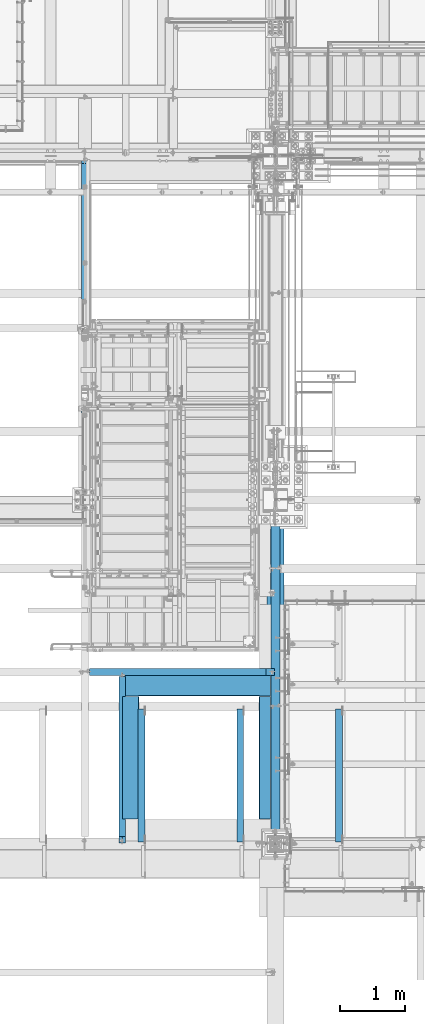
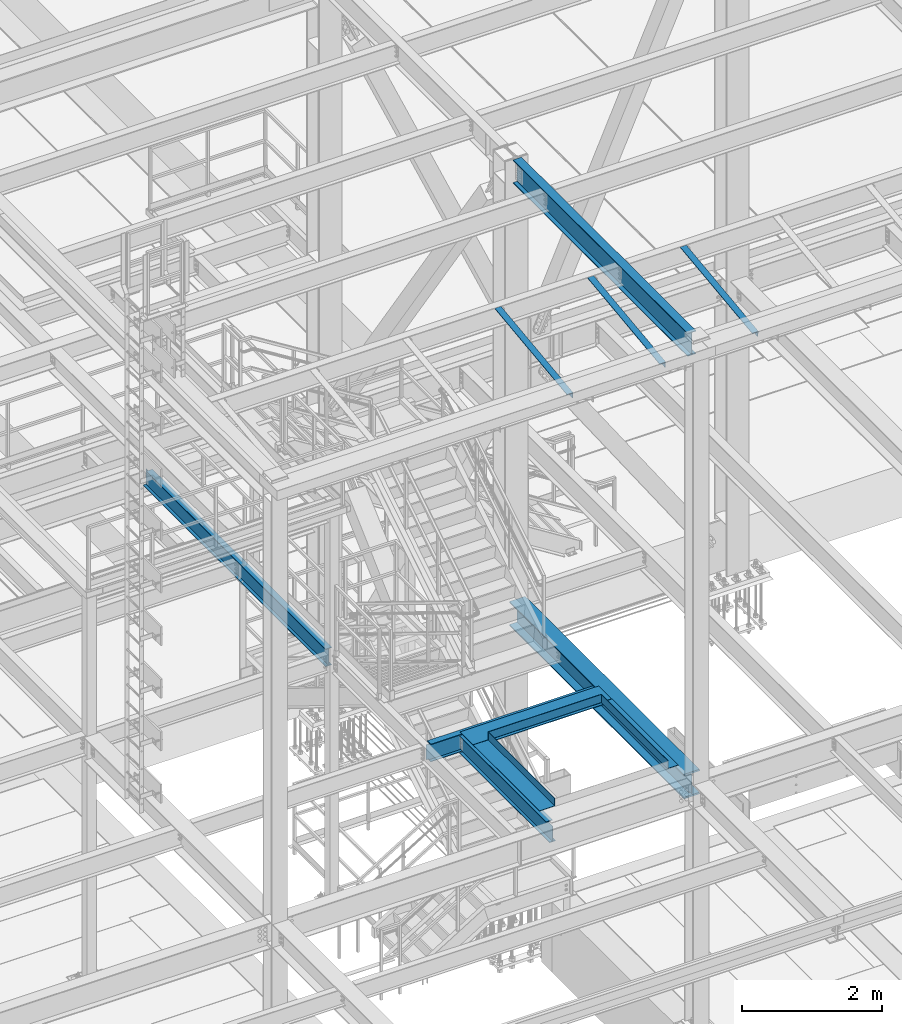
# One storey, part 1760 of 3843: 11 beams, 11 elements without a shape of their own.
"""IFC2X3 building model written with IfcOpenShell, lengths in millimetres."""

from ifc_helpers import new_model, si_unit, frame, origin_with_axes, place, context, subcontext, project, spatial, faceted_brep, material, type_object, element, aggregate, save


model = new_model("IFC2X3")

# Units and contexts
model_context = context("Model", 3, precision=1e-05, world=origin_with_axes())
body_context = subcontext(model_context, "Body", "Model", "MODEL_VIEW")
ifc_project = project(units=[si_unit("LENGTHUNIT", "METRE", prefix="MILLI"), si_unit("AREAUNIT", "SQUARE_METRE"), si_unit("VOLUMEUNIT", "CUBIC_METRE"), si_unit("MASSUNIT", "GRAM", prefix="KILO"), si_unit("TIMEUNIT", "SECOND"), si_unit("PLANEANGLEUNIT", "RADIAN"), si_unit("SOLIDANGLEUNIT", "STERADIAN"), si_unit("THERMODYNAMICTEMPERATUREUNIT", "DEGREE_CELSIUS"), si_unit("LUMINOUSINTENSITYUNIT", "LUMEN")], contexts=[model_context])

# Site, building, storey
site_placement = place(None, origin_with_axes())
site = spatial("IfcSite", under=ifc_project, at=site_placement, CompositionType="ELEMENT")
building_placement = place(site_placement, origin_with_axes())
building = spatial("IfcBuilding", under=site, at=building_placement, Name="Undefined", CompositionType="ELEMENT")
storey_placement = place(building_placement, origin_with_axes())
storey = spatial("IfcBuildingStorey", under=building, at=storey_placement, Name="Undefined", CompositionType="ELEMENT", Elevation=0.0)

# Assembly, beam
assembly_1_placement = place(storey_placement, origin_with_axes())
assembly_1 = element("IfcElementAssembly", 1, at=assembly_1_placement, inside=storey, Name="ANGLE", AssemblyPlace="NOTDEFINED", PredefinedType="RIGID_FRAME")
ifc_material_1 = material(Name="STEEL/A572-50")
beam_type_1 = type_object("IfcBeamType", Name="L4X4X3/8", PredefinedType="NOTDEFINED")
beam_1_placement = place(assembly_1_placement, frame((56910.2875, 17090.2662426835, 42392.9829998706), z_axis=(-1.0, 0.0, 0.0), x_axis=(0.0, -0.99246063250399, -0.122563832062241)))
beam_1 = element("IfcBeam", 2, at=beam_1_placement, type_object=beam_type_1, material=ifc_material_1, Name="ANGLE", ObjectType="L4X4X3/8", context=body_context, shape_type="Brep", body=[
    faceted_brep([(0.0, 50.8000000000029, -50.8000000000029), (0.0, 50.8000000000029, 50.8000000000029), (2072.3895061554, 50.8000000024476, 50.8000000000029), (2072.3895061554, 50.8000000024476, -50.8000000000029), (0.0, 41.2750000000015, 50.8000000000029), (2072.38950615541, 41.2750000024098, 50.8000000000029), (0.0, 41.2749999999942, -41.2750000000015), (2072.38950615541, 41.2750000024098, -41.2750000000015), (0.0, -50.8000000000029, -41.2750000000015), (2072.38950615556, -50.7999999979074, -41.2750000000015), (0.0, -50.8000000000029, -50.8000000000029), (2072.38950615556, -50.7999999979074, -50.8000000000029)], [[[0, 1, 2, 3]], [[1, 4, 5, 2]], [[4, 6, 7, 5]], [[6, 8, 9, 7]], [[8, 10, 11, 9]], [[10, 0, 3, 11]], [[5, 7, 9, 11, 3, 2]], [[10, 8, 6, 4, 1, 0]]]),
])
aggregate(assembly_1, [beam_1])

assembly_2_placement = place(storey_placement, origin_with_axes())
assembly_2 = element("IfcElementAssembly", 3, at=assembly_2_placement, inside=storey, Name="ANGLE", AssemblyPlace="NOTDEFINED", PredefinedType="RIGID_FRAME")
beam_2_placement = place(assembly_2_placement, frame((55386.2875, 17090.2662426835, 42392.9829998706), z_axis=(-1.0, 0.0, 0.0), x_axis=(0.0, -0.99246063250399, -0.122563832062241)))
beam_2 = element("IfcBeam", 4, at=beam_2_placement, type_object=beam_type_1, material=ifc_material_1, Name="ANGLE", ObjectType="L4X4X3/8", context=body_context, shape_type="Brep", body=[
    faceted_brep([(0.0, 50.8000000000029, -50.8000000000029), (0.0, 50.8000000000029, 50.8000000000029), (2072.3895061554, 50.8000000024476, 50.8000000000029), (2072.3895061554, 50.8000000024476, -50.8000000000029), (0.0, 41.2750000000015, 50.8000000000029), (2072.38950615541, 41.2750000024098, 50.8000000000029), (0.0, 41.2749999999942, -41.2750000000015), (2072.38950615541, 41.2750000024098, -41.2750000000015), (0.0, -50.8000000000029, -41.2750000000015), (2072.38950615556, -50.7999999979074, -41.2750000000015), (0.0, -50.8000000000029, -50.8000000000029), (2072.38950615556, -50.7999999979074, -50.8000000000029)], [[[0, 1, 2, 3]], [[1, 4, 5, 2]], [[4, 6, 7, 5]], [[6, 8, 9, 7]], [[8, 10, 11, 9]], [[10, 0, 3, 11]], [[5, 7, 9, 11, 3, 2]], [[10, 8, 6, 4, 1, 0]]]),
])
aggregate(assembly_2, [beam_2])

assembly_3_placement = place(storey_placement, origin_with_axes())
assembly_3 = element("IfcElementAssembly", 5, at=assembly_3_placement, inside=storey, Name="ANGLE", AssemblyPlace="NOTDEFINED", PredefinedType="RIGID_FRAME")
beam_3_placement = place(assembly_3_placement, frame((53862.2875, 17090.2662426835, 42392.9829998706), z_axis=(-1.0, 0.0, 0.0), x_axis=(0.0, -0.99246063250399, -0.122563832062241)))
beam_3 = element("IfcBeam", 6, at=beam_3_placement, type_object=beam_type_1, material=ifc_material_1, Name="ANGLE", ObjectType="L4X4X3/8", context=body_context, shape_type="Brep", body=[
    faceted_brep([(0.0, 50.8000000000029, -50.8000000000029), (0.0, 50.8000000000029, 50.8000000000029), (2072.3895061554, 50.8000000024476, 50.8000000000029), (2072.3895061554, 50.8000000024476, -50.8000000000029), (0.0, 41.2750000000015, 50.8000000000029), (2072.38950615541, 41.2750000024098, 50.8000000000029), (0.0, 41.2749999999942, -41.2750000000015), (2072.38950615541, 41.2750000024098, -41.2750000000015), (0.0, -50.8000000000029, -41.2750000000015), (2072.38950615556, -50.7999999979074, -41.2750000000015), (0.0, -50.8000000000029, -50.8000000000029), (2072.38950615556, -50.7999999979074, -50.8000000000029)], [[[0, 1, 2, 3]], [[1, 4, 5, 2]], [[4, 6, 7, 5]], [[6, 8, 9, 7]], [[8, 10, 11, 9]], [[10, 0, 3, 11]], [[5, 7, 9, 11, 3, 2]], [[10, 8, 6, 4, 1, 0]]]),
])
aggregate(assembly_3, [beam_3])

assembly_4_placement = place(storey_placement, origin_with_axes())
assembly_4 = element("IfcElementAssembly", 7, at=assembly_4_placement, inside=storey, Name="BEAM", AssemblyPlace="NOTDEFINED", PredefinedType="RIGID_FRAME")
ifc_material_2 = material(Name="STEEL/A992")
beam_type_2 = type_object("IfcBeamType", Name="W12X19", PredefinedType="NOTDEFINED")
beam_4_placement = place(assembly_4_placement, frame((53568.6, 14998.7, 34656.7125), z_axis=(0.0, 0.0, 1.0), x_axis=(0.0, 1.0, 0.0)))
beam_4 = element("IfcBeam", 8, at=beam_4_placement, type_object=beam_type_2, material=ifc_material_2, Name="BEAM", ObjectType="W12X19", context=body_context, shape_type="Brep", body=[
    faceted_brep([(100.012500190724, -3.17500000000291, 122.237500000003), (100.012500190724, 3.17500000000291, 122.237500000003), (17.4624999999942, 3.17500000000291, 122.237500000003), (17.4624999999942, -3.17500000000291, 122.237500000003), (104.87257970877, -3.17500000000291, 123.204229922594), (104.87257970877, 3.17500000000291, 123.204229922594), (108.992756176924, -3.17500000000291, 125.957243823068), (108.992756176924, 3.17500000000291, 125.957243823068), (111.745770077401, -3.17500000000291, 130.077420291222), (111.745770077401, 3.17500000000291, 130.077420291222), (112.712499999989, -3.17500000000291, 134.937499809268), (112.712499999989, 3.17500000000291, 134.937499809268), (112.712499999989, -50.8000000000029, 153.987500000003), (112.712499999989, 50.8000000000029, 153.987500000003), (112.712499999989, 50.8000000000029, 144.462500000001), (112.712499999989, 3.17500000000291, 144.462500000001), (112.712499999989, -3.17500000000291, 144.462500000001), (112.712499999989, -50.8000000000029, 144.462500000001), (17.4624999999942, -3.17500000000291, -144.462500000001), (17.4624999999942, -50.8000000000029, -144.462500000001), (2587.625, -50.8000000000029, -144.462500000001), (2587.625, -3.17500000000291, -144.462500000001), (17.4624999999942, -50.8000000000029, -153.987500000003), (2587.625, -50.8000000000029, -153.987500000003), (17.4624999999942, 50.8000000000029, -153.987500000003), (2587.625, 50.8000000000029, -153.987500000003), (17.4624999999942, 50.8000000000029, -144.462500000001), (2587.625, 50.8000000000029, -144.462500000001), (17.4624999999942, 3.17500000000291, -144.462500000001), (2587.625, 3.17500000000291, -144.462500000001), (2587.625, 3.17500000000291, -141.287499809252), (2587.625, -3.17500000000291, -141.287499809252), (2588.59172992259, 3.17500000000291, -136.427420291206), (2588.59172992259, -3.17500000000291, -136.427420291206), (2591.34474382307, 3.17500000000291, -132.307243823052), (2591.34474382307, -3.17500000000291, -132.307243823052), (2595.46492029122, 3.17500000000291, -129.554229922578), (2595.46492029122, -3.17500000000291, -129.554229922578), (2600.32499980927, 3.17500000000291, -128.587499999987), (2600.32499980927, -3.17500000000291, -128.587499999987), (2638.425, -3.17500000000291, -128.587499999987), (2638.425, 3.17500000000291, -128.587499999987), (2638.425, 3.17500000000291, -114.712500000001), (2638.425, 3.17500000000291, 115.887499999997), (2638.425, 3.17500000000291, 128.587500000016), (2638.425, -3.17500000000291, 128.587500000016), (2600.32499980927, 3.17500000000291, 128.587500000016), (2600.32499980927, -3.17500000000291, 128.587500000016), (2595.46492029122, 3.17500000000291, 129.554229922607), (2595.46492029122, -3.17500000000291, 129.554229922607), (2591.34474382307, 3.17500000000291, 132.307243823081), (2591.34474382307, -3.17500000000291, 132.307243823081), (2588.59172992259, 3.17500000000291, 136.427420291235), (2588.59172992259, -3.17500000000291, 136.427420291235), (2587.625, 3.17500000000291, 141.287499809281), (2587.625, -3.17500000000291, 141.287499809281), (2587.625, -50.8000000000029, 153.987500000003), (2587.625, -50.8000000000029, 144.462500000001), (2587.625, -3.17500000000291, 144.462500000001), (2587.625, 3.17500000000291, 144.462500000001), (2587.625, 50.8000000000029, 144.462500000001), (2587.625, 50.8000000000029, 153.987500000003), (17.4624999999942, 3.17500000000291, 115.887499999997), (17.4624999999942, 3.17500000000291, -114.712500000001)], [[[0, 1, 2, 3]], [[4, 5, 1, 0]], [[6, 7, 5, 4]], [[8, 9, 7, 6]], [[10, 11, 9, 8]], [[12, 13, 14, 15, 11, 10, 16, 17]], [[18, 19, 20, 21]], [[19, 22, 23, 20]], [[22, 24, 25, 23]], [[24, 26, 27, 25]], [[26, 28, 29, 27]], [[21, 20, 23, 25, 27, 29, 30, 31]], [[31, 30, 32, 33]], [[33, 32, 34, 35]], [[35, 34, 36, 37]], [[37, 36, 38, 39]], [[40, 39, 38, 41]], [[42, 43, 44, 45, 40, 41]], [[45, 44, 46, 47]], [[47, 46, 48, 49]], [[49, 48, 50, 51]], [[51, 50, 52, 53]], [[53, 52, 54, 55]], [[56, 57, 58, 55, 54, 59, 60, 61]], [[57, 56, 12, 17]], [[58, 57, 17, 16]], [[8, 6, 4, 0, 3, 18, 21, 31, 33, 35, 37, 39, 40, 45, 47, 49, 51, 53, 55, 58, 16, 10]], [[62, 63, 28, 26, 24, 22, 19, 18, 3, 2]], [[59, 54, 52, 50, 48, 46, 44, 43, 42, 41, 38, 36, 34, 32, 30, 29, 28, 63, 62, 2, 1, 5, 7, 9, 11, 15]], [[60, 59, 15, 14]], [[61, 60, 14, 13]], [[56, 61, 13, 12]]]),
])
aggregate(assembly_4, [beam_4])

assembly_5_placement = place(storey_placement, origin_with_axes())
assembly_5 = element("IfcElementAssembly", 9, at=assembly_5_placement, inside=storey, Name="BEAM", AssemblyPlace="NOTDEFINED", PredefinedType="RIGID_FRAME")
beam_5_placement = place(assembly_5_placement, frame((52990.75, 17653.0, 34656.7125), z_axis=(0.0, 0.0, 1.0), x_axis=(1.0, 0.0, 0.0)))
beam_5 = element("IfcBeam", 10, at=beam_5_placement, type_object=beam_type_2, material=ifc_material_2, Name="BEAM", ObjectType="W12X19", context=body_context, shape_type="Brep", body=[
    faceted_brep([(2794.79375, -50.7999999999993, 153.987500000003), (2794.79375, -50.7999999999993, 144.462500000001), (2794.79375, -3.17499999999927, 144.462500000001), (2794.79375, -3.17499999999927, 134.937499809275), (2794.79375, 3.17499999999927, 134.937499809275), (2794.79375, 3.17499999999927, 144.462500000001), (2794.79375, 50.7999999999993, 144.462500000001), (2794.79375, 50.7999999999993, 153.987500000003), (2795.7604799226, -3.17499999999927, 130.077420291229), (2795.7604799226, 3.17499999999927, 130.077420291229), (2798.51349382307, -3.17499999999927, 125.957243823075), (2798.51349382307, 3.17499999999927, 125.957243823075), (2802.63367029122, -3.17499999999927, 123.204229922601), (2802.63367029122, 3.17499999999927, 123.204229922601), (2807.49374980927, -3.17499999999927, 122.23750000001), (2807.49374980927, 3.17499999999927, 122.23750000001), (2921.79375, -3.17499999999927, 122.23750000001), (2921.79375, 3.17499999999927, 122.23750000001), (66.6750000000175, -50.8000000000029, 153.987500000003), (66.6750000000175, 50.8000000000029, 153.987500000003), (66.6750000000175, 50.8000000000029, 144.462500000001), (66.6750000000175, 3.17500000000291, 144.462500000001), (66.6750000000175, 3.17500000000291, 141.287499810307), (66.6750000000175, -3.17500000000291, 141.287499810307), (66.6750000000175, -3.17500000000291, 144.462500000001), (66.6750000000175, -50.8000000000029, 144.462500000001), (65.7082700774336, 3.17500000000291, 136.427420292261), (65.7082700774336, -3.17500000000291, 136.427420292261), (62.9552561769524, 3.17500000000291, 132.307243824107), (62.9552561769524, -3.17500000000291, 132.307243824107), (58.8350797087915, 3.17500000000291, 129.554229923633), (58.8350797087915, -3.17500000000291, 129.554229923633), (53.9750001907523, 3.17500000000291, 128.587500001042), (53.9750001907523, -3.17500000000291, 128.587500001042), (15.8750000000146, 3.17500000000291, 128.587500001042), (15.8750000000146, -3.17500000000291, 128.587500001042), (15.8750000000146, 3.17500000000291, 115.887500001612), (15.8750000000146, 3.17500000000291, -114.712499998386), (15.8750000000146, 3.17500000000291, -128.587499998961), (15.8750000000146, -3.17500000000291, -128.587499998961), (53.9750001907523, 3.17500000000291, -128.587499998961), (53.9750001907523, -3.17500000000291, -128.587499998961), (58.8350797087915, 3.17500000000291, -129.554229921552), (58.8350797087915, -3.17500000000291, -129.554229921552), (62.9552561769524, 3.17500000000291, -132.307243822026), (62.9552561769524, -3.17500000000291, -132.307243822026), (65.7082700774336, 3.17500000000291, -136.42742029018), (65.7082700774336, -3.17500000000291, -136.42742029018), (66.6750000000175, 3.17500000000291, -141.287499808226), (66.6750000000175, -3.17500000000291, -141.287499808226), (2921.79375, 3.17499999999927, -144.462500000001), (2921.79375, 50.7999999999993, -144.462500000001), (66.6750000000175, 50.8000000000029, -144.462500000001), (66.6750000000175, 3.17500000000291, -144.462500000001), (2921.79375, 50.7999999999993, -153.987500000003), (66.6750000000175, 50.8000000000029, -153.987500000003), (2921.79375, -50.7999999999993, -153.987500000003), (66.6750000000175, -50.8000000000029, -153.987500000003), (2921.79375, -50.7999999999993, -144.462500000001), (66.6750000000175, -50.8000000000029, -144.462500000001), (66.6750000000175, -3.17500000000291, -144.462500000001), (2921.79375, -3.17499999999927, -144.462500000001), (2921.79375, 3.17499999999927, 115.887499999997), (2921.79375, 3.17499999999927, -114.712500000001)], [[[0, 1, 2, 3, 4, 5, 6, 7]], [[8, 9, 4, 3]], [[10, 11, 9, 8]], [[12, 13, 11, 10]], [[14, 15, 13, 12]], [[16, 17, 15, 14]], [[18, 19, 20, 21, 22, 23, 24, 25]], [[23, 22, 26, 27]], [[27, 26, 28, 29]], [[29, 28, 30, 31]], [[31, 30, 32, 33]], [[33, 32, 34, 35]], [[35, 34, 36, 37, 38, 39]], [[39, 38, 40, 41]], [[41, 40, 42, 43]], [[43, 42, 44, 45]], [[45, 44, 46, 47]], [[47, 46, 48, 49]], [[50, 51, 52, 53]], [[51, 54, 55, 52]], [[54, 56, 57, 55]], [[56, 58, 59, 57]], [[49, 48, 53, 52, 55, 57, 59, 60]], [[58, 61, 60, 59]], [[61, 16, 14, 12, 10, 8, 3, 2, 24, 23, 27, 29, 31, 33, 35, 39, 41, 43, 45, 47, 49, 60]], [[2, 1, 25, 24]], [[1, 0, 18, 25]], [[0, 7, 19, 18]], [[7, 6, 20, 19]], [[6, 5, 21, 20]], [[44, 42, 40, 38, 37, 36, 34, 32, 30, 28, 26, 22, 21, 5, 4, 9, 11, 13, 15, 17, 62, 63, 50, 53, 48, 46]], [[61, 58, 56, 54, 51, 50, 63, 62, 17, 16]]]),
])
aggregate(assembly_5, [beam_5])

assembly_6_placement = place(storey_placement, origin_with_axes())
assembly_6 = element("IfcElementAssembly", 11, at=assembly_6_placement, inside=storey, Name="BEAM", AssemblyPlace="NOTDEFINED", PredefinedType="RIGID_FRAME")
beam_6_placement = place(assembly_6_placement, frame((52990.75, 20307.3, 34656.7125), z_axis=(0.0, 0.0, 1.0), x_axis=(0.0, 1.0, 0.0)))
beam_6 = element("IfcBeam", 12, at=beam_6_placement, type_object=beam_type_2, material=ifc_material_2, Name="BEAM", ObjectType="W12X19", context=body_context, shape_type="Brep", body=[
    faceted_brep([(88.8999999999942, -3.17499999999927, -144.462500000001), (88.8999999999942, -50.7999999999993, -144.462500000001), (5291.1375, -50.8000000000029, -144.462500000001), (5291.1375, -3.17500000000291, -144.462500000001), (88.8999999999942, -50.7999999999993, -153.987500000003), (5291.1375, -50.8000000000029, -153.987500000003), (88.8999999999942, 50.7999999999993, -153.987500000003), (5291.1375, 50.8000000000029, -153.987500000003), (88.8999999999942, 50.7999999999993, -144.462500000001), (88.8999999999942, 3.17499999999927, -144.462500000001), (5291.1375, 3.17500000000291, -144.462500000001), (5291.1375, 50.8000000000029, -144.462500000001), (5291.1375, 3.17500000000291, -114.712500000001), (5291.1375, 3.17500000000291, 115.887499999997), (5291.1375, 3.17500000000291, 122.237500000003), (5291.1375, -3.17500000000291, 122.237500000003), (88.8999999999942, -3.17499999999927, 144.462500000001), (88.8999999999942, -50.7999999999993, 144.462500000001), (88.8999999999942, -50.7999999999993, 153.987500000003), (88.8999999999942, 50.7999999999993, 153.987500000003), (88.8999999999942, 50.7999999999993, 144.462500000001), (88.8999999999942, 3.17499999999927, 144.462500000001), (5195.8875, 50.8000000000029, 144.462500000001), (5195.8875, 3.17500000000291, 144.462500000001), (5195.8875, 3.17500000000291, 134.937499809268), (5196.85422992259, 3.17500000000291, 130.077420291222), (5199.60724382307, 3.17500000000291, 125.957243823068), (5203.72742029122, 3.17500000000291, 123.204229922594), (5208.58749980927, 3.17500000000291, 122.237500000003), (5196.85422992259, -3.17500000000291, 130.077420291222), (5195.8875, -3.17500000000291, 134.937499809268), (5199.60724382307, -3.17500000000291, 125.957243823068), (5203.72742029122, -3.17500000000291, 123.204229922594), (5208.58749980927, -3.17500000000291, 122.237500000003), (5195.8875, -3.17500000000291, 144.462500000001), (5195.8875, -50.8000000000029, 144.462500000001), (5195.8875, -50.8000000000029, 153.987500000003), (5195.8875, 50.8000000000029, 153.987500000003)], [[[0, 1, 2, 3]], [[1, 4, 5, 2]], [[4, 6, 7, 5]], [[8, 9, 10, 11]], [[3, 2, 5, 7, 11, 10, 12, 13, 14, 15]], [[6, 8, 11, 7]], [[4, 1, 0, 16, 17, 18, 19, 20, 21, 9, 8, 6]], [[21, 20, 22, 23]], [[13, 12, 10, 9, 21, 23, 24, 25, 26, 27, 28, 14]], [[29, 25, 24, 30]], [[31, 26, 25, 29]], [[32, 27, 26, 31]], [[33, 28, 27, 32]], [[15, 14, 28, 33]], [[32, 31, 29, 30, 34, 16, 0, 3, 15, 33]], [[17, 16, 34, 35]], [[18, 17, 35, 36]], [[19, 18, 36, 37]], [[20, 19, 37, 22]], [[36, 35, 34, 30, 24, 23, 22, 37]]]),
])
aggregate(assembly_6, [beam_6])

assembly_7_placement = place(storey_placement, origin_with_axes())
assembly_7 = element("IfcElementAssembly", 13, at=assembly_7_placement, inside=storey, AssemblyPlace="NOTDEFINED", PredefinedType="RIGID_FRAME")
beam_type_3 = type_object("IfcBeamType", PredefinedType="NOTDEFINED")
beam_7_placement = place(assembly_7_placement, frame((55851.425, 16332.0852929656, 34813.875), z_axis=(0.0, -1.0, 0.0), x_axis=(-1.0, 0.0, 0.0)))
beam_7 = element("IfcBeam", 14, at=beam_7_placement, type_object=beam_type_3, material=ifc_material_1, context=body_context, shape_type="Brep", body=[
    faceted_brep([(0.0, -3.17500000000291, -946.264499999999), (0.0, -3.17500000000291, 946.264499999999), (0.0, 3.17500000000291, 946.264499999999), (0.0, 3.17500000000291, -946.264499999999), (174.624999999993, 3.17500000001019, 946.264499999999), (174.624999999993, 3.17500000001019, -946.264499999999), (168.274999999987, -3.17499999999563, -946.264499999999), (168.274999999987, -3.17499999999563, 946.264499999999), (174.625, -136.524996948247, 946.264499999999), (174.625, -136.524996948247, -946.264499999999), (168.274999999994, -136.524996948247, 946.264499999999), (168.274999999994, -136.524996948247, -946.264499999999)], [[[0, 1, 2, 3]], [[3, 2, 4, 5]], [[1, 0, 6, 7]], [[5, 4, 8, 9]], [[4, 2, 1, 7, 10, 8]], [[7, 6, 11, 10]], [[6, 0, 3, 5, 9, 11]], [[10, 11, 9, 8]]]),
])
aggregate(assembly_7, [beam_7])

assembly_8_placement = place(storey_placement, origin_with_axes())
assembly_8 = element("IfcElementAssembly", 15, at=assembly_8_placement, inside=storey, AssemblyPlace="NOTDEFINED", PredefinedType="RIGID_FRAME")
beam_type_4 = type_object("IfcBeamType", PredefinedType="NOTDEFINED")
beam_8_placement = place(assembly_8_placement, frame((54709.6155, 17653.0, 34813.875), z_axis=(-1.0, 0.0, 0.0), x_axis=(0.0, -1.0, 0.0)))
beam_8 = element("IfcBeam", 16, at=beam_8_placement, type_object=beam_type_4, material=ifc_material_1, context=body_context, shape_type="Brep", body=[
    faceted_brep([(368.299987792925, 3.17500610351999, -973.534500000002), (361.949987792927, 3.17499999999563, -973.534500000002), (361.949987792934, 136.524996948283, -973.534500000002), (368.299987792932, 136.524996948283, -973.534500000002), (368.299987792925, 3.17500610351999, -1141.0155), (361.949987792927, 3.17499999999563, -1141.0155), (0.0, 3.17500000000291, -973.534500000002), (0.0, 3.17500000000291, -1141.0155), (0.0, -3.17500000000291, -1141.0155), (0.0, -3.17500000000291, 1141.0155), (0.0, 3.17500000000291, 1141.0155), (0.0, 3.17500000000291, 893.365500000014), (368.299987792925, -3.17500000001019, -1141.0155), (368.299987792925, -3.17500000001019, 1141.0155), (368.299987792925, 3.17500610351271, 1141.0154938965), (361.949987792927, 3.17499999999563, 1141.0155), (368.299987792925, 3.17500610351271, 893.365500000014), (361.949987792927, 3.17499999999563, 893.365500000014), (368.299987792932, 136.524996948283, 893.365500000014), (361.949987792934, 136.524996948283, 893.365500000014)], [[[0, 1, 2, 3]], [[4, 5, 1, 0]], [[6, 7, 8, 9, 10, 11]], [[9, 8, 12, 13]], [[10, 9, 13, 14, 15]], [[14, 16, 17, 15]], [[18, 19, 17, 16]], [[19, 18, 3, 2]], [[17, 19, 2, 1]], [[7, 6, 11, 10, 15, 17, 1, 5]], [[12, 8, 7, 5, 4]], [[18, 16, 14, 13, 12, 4, 0, 3]]]),
])
aggregate(assembly_8, [beam_8])

assembly_9_placement = place(storey_placement, origin_with_axes())
assembly_9 = element("IfcElementAssembly", 17, at=assembly_9_placement, inside=storey, AssemblyPlace="NOTDEFINED", PredefinedType="RIGID_FRAME")
beam_type_5 = type_object("IfcBeamType", PredefinedType="NOTDEFINED")
beam_9_placement = place(assembly_9_placement, frame((53568.6, 16332.1995, 34813.875), z_axis=(0.0, -1.0, 0.0), x_axis=(1.0, 0.0, 0.0)))
beam_9 = element("IfcBeam", 18, at=beam_9_placement, type_object=beam_type_5, material=ifc_material_1, context=body_context, shape_type="Brep", body=[
    faceted_brep([(0.0, -3.17500000000291, -946.15), (0.0, -3.17500000000291, 946.15), (0.0, 3.17500000000291, 946.15), (0.0, 3.17500000000291, -946.15), (247.64999999998, 3.17500000000291, 946.15), (247.64999999998, 3.17500000000291, -946.15), (253.999999999985, -3.17500000000291, -946.15), (253.999999999985, -3.17500000000291, 946.15), (247.649999999972, 136.524996948261, 946.15), (247.649999999972, 136.524996948261, -946.15), (253.999999999978, 136.524996948261, 946.15), (253.999999999978, 136.524996948261, -946.15)], [[[0, 1, 2, 3]], [[3, 2, 4, 5]], [[1, 0, 6, 7]], [[5, 4, 8, 9]], [[4, 2, 1, 7, 10, 8]], [[7, 6, 11, 10]], [[6, 0, 3, 5, 9, 11]], [[10, 11, 9, 8]]]),
])
aggregate(assembly_9, [beam_9])

assembly_10_placement = place(storey_placement, origin_with_axes())
assembly_10 = element("IfcElementAssembly", 19, at=assembly_10_placement, inside=storey, Name="BEAM", AssemblyPlace="NOTDEFINED", PredefinedType="RIGID_FRAME")
beam_type_6 = type_object("IfcBeamType", Name="W16X31", PredefinedType="NOTDEFINED")
beam_10_placement = place(assembly_10_placement, frame((55930.8, 14998.7, 42267.1875), z_axis=(0.0, 0.0, 1.0), x_axis=(0.0, 1.0, 0.0)))
beam_10 = element("IfcBeam", 20, at=beam_10_placement, type_object=beam_type_6, material=ifc_material_2, Name="BEAM", ObjectType="W16X31", context=body_context, shape_type="Brep", body=[
    faceted_brep([(142.874999999996, -69.8499999999985, -201.612500000003), (142.874999999996, 69.8499999999985, -201.612500000003), (5116.5125, 69.8499999999985, -201.612500000003), (5116.5125, -69.8499999999985, -201.612500000003), (142.874999999996, -69.8499999999985, -190.5), (142.874999999996, -3.17500000000291, -190.5), (142.874999999996, -3.17500000000291, 190.5), (142.874999999996, -69.8499999999985, 190.5), (142.874999999996, -69.8499999999985, 201.612500000003), (142.874999999996, 69.8499999999985, 201.612500000003), (142.874999999996, 69.8499999999985, 190.5), (142.874999999996, 3.17500000000291, 190.5), (142.874999999996, 3.17500000000291, -190.5), (142.874999999996, 69.8499999999985, -190.5), (5116.5125, -69.8499999999985, -190.5), (5116.5125, -3.17500000000291, -190.5), (5116.5125, -3.17500000000291, 190.5), (5116.5125, -69.8499999999985, 190.5), (5116.5125, -69.8499999999985, 201.612500000003), (5116.5125, 69.8499999999985, 201.612500000003), (5116.5125, 69.8499999999985, 190.5), (5116.5125, 3.17500000000291, 190.5), (5116.5125, 3.17500000000291, -190.5), (5116.5125, 69.8499999999985, -190.5)], [[[0, 1, 2, 3]], [[0, 4, 5, 6, 7, 8, 9, 10, 11, 12, 13, 1]], [[5, 4, 14, 15]], [[6, 5, 15, 16]], [[7, 6, 16, 17]], [[8, 7, 17, 18]], [[9, 8, 18, 19]], [[10, 9, 19, 20]], [[11, 10, 20, 21]], [[12, 11, 21, 22]], [[13, 12, 22, 23]], [[1, 13, 23, 2]], [[22, 21, 20, 19, 18, 17, 16, 15, 14, 3, 2, 23]], [[4, 0, 3, 14]]]),
])
aggregate(assembly_10, [beam_10])

assembly_11_placement = place(storey_placement, origin_with_axes())
assembly_11 = element("IfcElementAssembly", 21, at=assembly_11_placement, inside=storey, Name="BEAM", AssemblyPlace="NOTDEFINED", PredefinedType="RIGID_FRAME")
beam_type_7 = type_object("IfcBeamType", Name="W16X77", PredefinedType="NOTDEFINED")
beam_11_placement = place(assembly_11_placement, frame((55930.8, 14998.7, 34601.15), z_axis=(0.0, 0.0, 1.0), x_axis=(0.0, 1.0, 0.0)))
beam_11 = element("IfcBeam", 22, at=beam_11_placement, type_object=beam_type_7, material=ifc_material_2, Name="BEAM", ObjectType="W16X77", context=body_context, shape_type="Brep", body=[
    faceted_brep([(150.698581967608, -130.175000000003, 209.550000000003), (150.698581967608, 130.175000000003, 209.550000000003), (139.699999999999, 130.175000000003, 190.5), (139.699999999999, 5.55624999999418, 190.5), (139.699999999999, -5.55624999999418, 190.5), (139.699999999999, -130.175000000003, 190.5), (5116.5125, 5.55625000000146, -190.5), (5116.5125, 130.175000000003, -190.5), (150.69859824655, 130.175000000003, -190.5), (150.69859824655, 5.55624999999418, -190.5), (5116.5125, -130.175000000003, -209.550000000003), (5116.5125, -130.175000000003, -190.5), (150.69859824655, -130.175000000003, -190.5), (139.699999999999, -130.175000000003, -209.550000000003), (5116.5125, 130.175000000003, -209.550000000003), (139.699999999999, 130.175000000003, -209.550000000003), (5116.5125, 5.55625000000146, 190.5), (5116.5125, 130.175000000003, 190.5), (5116.5125, 130.175000000003, 209.550000000003), (5116.5125, -130.175000000003, 209.550000000003), (5116.5125, -130.175000000003, 190.5), (5116.5125, -5.55625000000146, 190.5), (5116.5125, -5.55625000000146, -190.5), (139.699999999999, 5.55624999999418, 190.102999496463), (139.699999999999, -5.55624999999418, 190.102999496463), (165.10000152588, 5.55624999999418, 190.102999496463), (165.10000152588, -5.55624999999418, 190.102999496463), (211.693448365435, 5.55624999999418, 180.79025946014), (211.693448365435, -5.55624999999418, 180.79025946014), (216.566753565228, 5.55624999999418, 178.180215038927), (216.566753565228, -5.55624999999418, 178.180215038927), (219.169596365356, 5.55624999999418, 173.303059637583), (219.169596365356, -5.55624999999418, 173.303059637583), (218.62519450505, 5.55624999999418, 167.801690529304), (218.62519450505, -5.55624999999418, 167.801690529304), (215.116932817931, 5.55624999999418, 163.52927489108), (215.116932817931, -5.55624999999418, 163.52927489108), (209.826589017679, 5.55624999999418, 161.925000000003), (209.826589017679, -5.55624999999418, 161.925000000003), (142.874999999987, 5.55624999999418, 161.925000000003), (142.874999999987, -5.55624999999418, 161.925000000003), (142.874999999987, 5.55624999999418, -161.925000000003), (142.874999999987, -5.55624999999418, -161.925000000003), (208.583589242771, 5.55624999999418, -161.925000000003), (208.583589242771, -5.55624999999418, -161.925000000003), (213.873933026549, 5.55624999999418, -163.529274880071), (213.873933026549, -5.55624999999418, -163.529274880071), (217.382194714966, 5.55624999999418, -167.801690492699), (217.382194714966, -5.55624999999418, -167.801690492699), (217.926596602014, 5.55624999999418, -173.303059579281), (217.926596602014, -5.55624999999418, -173.303059579281), (215.323753846324, 5.55624999999418, -178.180214982844), (215.323753846324, -5.55624999999418, -178.180214982844), (210.450448687674, 5.55624999999418, -180.790259440721), (210.450448687674, -5.55624999999418, -180.790259440721), (163.857004272462, 5.55624999999418, -190.102999496463), (163.857004272462, -5.55624999999418, -190.102999496463), (150.927799780187, 5.55624999999418, -190.102999496463), (150.927799780187, -5.55624999999418, -190.102999496463), (150.69859824655, -5.55624999999418, -190.5)], [[[0, 1, 2, 3, 4, 5]], [[6, 7, 8, 9]], [[10, 11, 12, 13]], [[14, 10, 13, 15]], [[7, 14, 15, 8]], [[6, 16, 17, 18, 19, 20, 21, 22, 11, 10, 14, 7]], [[20, 19, 0, 5]], [[21, 20, 5, 4]], [[23, 24, 4, 3]], [[25, 26, 24, 23]], [[26, 25, 27, 28]], [[28, 27, 29, 30]], [[30, 29, 31, 32]], [[32, 31, 33, 34]], [[34, 33, 35, 36]], [[36, 35, 37, 38]], [[38, 37, 39, 40]], [[40, 39, 41, 42]], [[43, 44, 42, 41]], [[44, 43, 45, 46]], [[46, 45, 47, 48]], [[48, 47, 49, 50]], [[50, 49, 51, 52]], [[52, 51, 53, 54]], [[54, 53, 55, 56]], [[56, 55, 57, 58]], [[22, 21, 4, 24, 26, 28, 30, 32, 34, 36, 38, 40, 42, 44, 46, 48, 50, 52, 54, 56, 58, 59]], [[11, 22, 59, 12]], [[58, 57, 9, 8, 15, 13, 12, 59]], [[55, 53, 51, 49, 47, 45, 43, 41, 39, 37, 35, 33, 31, 29, 27, 25, 23, 3, 16, 6, 9, 57]], [[17, 16, 3, 2]], [[18, 17, 2, 1]], [[19, 18, 1, 0]]]),
])
aggregate(assembly_11, [beam_11])

save(model, "model.ifc")
